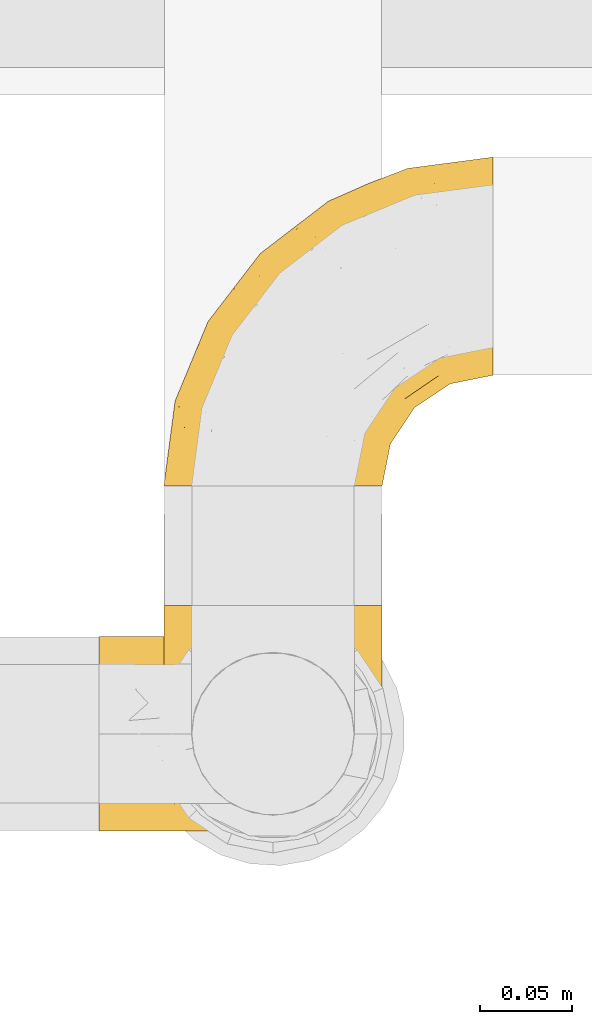
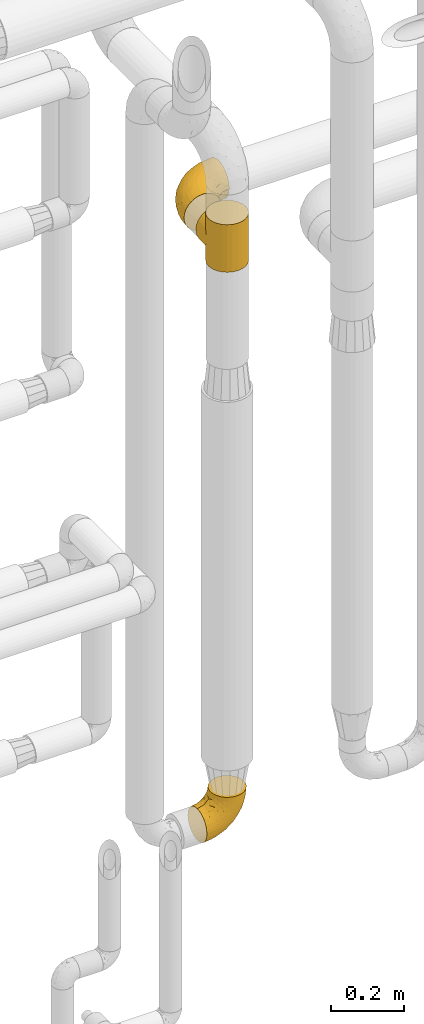
# One storey, part 462 of 827: 3 coverings.
"""IFC2X3 building model written with IfcOpenShell, lengths in millimetres."""

from ifc_helpers import new_model, entity, si_unit, converted_unit, derived_unit, direction, frame, origin, place, context, subcontext, project, spatial, faceted_brep, element, save


model = new_model("IFC2X3")

# Units and contexts
model_context = context("Model", 3, precision=0.01, world=origin(), true_north=direction((6.12303176911189e-17, 1.0)))
body_context = subcontext(model_context, "Body", "Model", "MODEL_VIEW")
ifc_project = project(units=[si_unit("LENGTHUNIT", "METRE", prefix="MILLI"), si_unit("AREAUNIT", "SQUARE_METRE"), si_unit("VOLUMEUNIT", "CUBIC_METRE"), converted_unit("PLANEANGLEUNIT", "DEGREE", entity("IfcRatioMeasure", 0.0174532925199433), si_unit("PLANEANGLEUNIT", "RADIAN"), dimensions=[0, 0, 0, 0, 0, 0, 0]), si_unit("MASSUNIT", "GRAM", prefix="KILO"), derived_unit("MASSDENSITYUNIT", [(si_unit("MASSUNIT", "GRAM", prefix="KILO"), 1), (si_unit("LENGTHUNIT", "METRE"), -3)]), derived_unit("MOMENTOFINERTIAUNIT", [(si_unit("LENGTHUNIT", "METRE"), 4)]), si_unit("TIMEUNIT", "SECOND"), si_unit("FREQUENCYUNIT", "HERTZ"), si_unit("THERMODYNAMICTEMPERATUREUNIT", "DEGREE_CELSIUS"), derived_unit("THERMALTRANSMITTANCEUNIT", [(si_unit("MASSUNIT", "GRAM", prefix="KILO"), 1), (si_unit("THERMODYNAMICTEMPERATUREUNIT", "KELVIN"), -1), (si_unit("TIMEUNIT", "SECOND"), -3)]), derived_unit("VOLUMETRICFLOWRATEUNIT", [(si_unit("LENGTHUNIT", "METRE"), 3), (si_unit("TIMEUNIT", "SECOND"), -1)]), derived_unit("MASSFLOWRATEUNIT", [(si_unit("MASSUNIT", "GRAM", prefix="KILO"), 1), (si_unit("TIMEUNIT", "SECOND"), -1)]), derived_unit("ROTATIONALFREQUENCYUNIT", [(si_unit("TIMEUNIT", "SECOND"), -1)]), si_unit("ELECTRICCURRENTUNIT", "AMPERE"), si_unit("ELECTRICVOLTAGEUNIT", "VOLT"), si_unit("POWERUNIT", "WATT"), si_unit("FORCEUNIT", "NEWTON", prefix="KILO"), si_unit("ILLUMINANCEUNIT", "LUX"), si_unit("LUMINOUSFLUXUNIT", "LUMEN"), si_unit("LUMINOUSINTENSITYUNIT", "CANDELA"), derived_unit("USERDEFINED", [(si_unit("MASSUNIT", "GRAM", prefix="KILO"), -1), (si_unit("LENGTHUNIT", "METRE"), -2), (si_unit("TIMEUNIT", "SECOND"), 3), (si_unit("LUMINOUSFLUXUNIT", "LUMEN"), 1)]), derived_unit("LINEARVELOCITYUNIT", [(si_unit("LENGTHUNIT", "METRE"), 1), (si_unit("TIMEUNIT", "SECOND"), -1)]), si_unit("PRESSUREUNIT", "PASCAL"), derived_unit("USERDEFINED", [(si_unit("LENGTHUNIT", "METRE"), -2), (si_unit("MASSUNIT", "GRAM", prefix="KILO"), 1), (si_unit("TIMEUNIT", "SECOND"), -2)]), derived_unit("LINEARFORCEUNIT", [(si_unit("MASSUNIT", "GRAM", prefix="KILO"), 1), (si_unit("LENGTHUNIT", "METRE"), 1), (si_unit("TIMEUNIT", "SECOND"), -2), (si_unit("LENGTHUNIT", "METRE"), -1)]), derived_unit("PLANARFORCEUNIT", [(si_unit("MASSUNIT", "GRAM", prefix="KILO"), 1), (si_unit("LENGTHUNIT", "METRE"), 1), (si_unit("TIMEUNIT", "SECOND"), -2), (si_unit("LENGTHUNIT", "METRE"), -2)])], contexts=[model_context])

# Site, building, storey
site_placement = place(None, origin())
site = spatial("IfcSite", under=ifc_project, at=site_placement, CompositionType="ELEMENT")
building_placement = place(site_placement, origin())
building = spatial("IfcBuilding", under=site, at=building_placement, CompositionType="ELEMENT")
storey_placement = place(building_placement, frame((0.0, 0.0, 28200.0)))
storey = spatial("IfcBuildingStorey", under=building, at=storey_placement, Name="08", CompositionType="ELEMENT", Elevation=28200.0)

# Coverings
covering_1_placement = place(storey_placement, frame((56988.97, 17438.9, 2220.0)))
element("IfcCovering", 1, at=covering_1_placement, inside=storey, Name=":ADSK_", ObjectType=":ADSK_", PredefinedType="INSULATION", context=body_context, shape_type="Brep", body=[
    faceted_brep([(120.05, 69.11, 71.99), (120.6, 61.1, 0.0), (118.57, 76.5, 0.0), (112.62, 90.85, 0.0), (115.66, 84.83, 56.27), (106.54, 99.5, 41.59), (103.17, 103.17, 0.0), (111.72, 92.36, 48.74), (120.6, 61.1, 80.0), (120.05, 69.11, 88.01), (120.6, 61.1, 160.0), (118.42, 77.05, 64.05), (100.03, 106.08, 35.01), (90.85, 112.62, 0.0), (82.85, 116.47, 24.62), (83.67, 115.6, 0.0), (76.5, 118.57, 0.0), (68.8, 119.58, 0.0), (61.1, 120.6, 0.0), (61.1, 120.6, 20.5), (68.8, 119.58, 160.0), (61.1, 120.6, 139.5), (61.1, 120.6, 160.0), (92.14, 111.85, 29.24), (72.35, 119.52, 21.57), (77.6, 118.0, 23.1), (66.72, 120.06, 21.04), (49.85, 119.52, 21.57), (53.4, 119.58, 0.0), (45.7, 118.57, 0.0), (39.34, 116.48, 24.62), (38.52, 115.6, 0.0), (31.35, 112.62, 0.0), (22.16, 106.09, 35.01), (19.02, 103.17, 0.0), (55.47, 120.06, 21.04), (53.4, 119.58, 160.0), (30.06, 111.86, 29.24), (44.6, 118.0, 23.1), (15.66, 99.51, 41.59), (10.47, 92.37, 48.73), (9.57, 90.85, 0.0), (6.54, 84.83, 56.26), (3.62, 76.5, 0.0), (2.14, 69.11, 71.99), (1.6, 61.1, 0.0), (3.77, 77.05, 64.05), (1.6, 61.1, 80.0), (2.14, 69.11, 88.01), (1.6, 61.1, 160.0), (31.35, 9.57, 160.0), (45.7, 3.62, 160.0), (61.1, 1.6, 160.0), (76.5, 3.62, 160.0), (90.85, 9.57, 160.0), (103.17, 19.02, 160.0), (112.62, 31.35, 160.0), (118.57, 45.7, 160.0), (118.57, 76.5, 160.0), (112.62, 90.85, 160.0), (103.17, 103.17, 160.0), (90.85, 112.62, 160.0), (83.67, 115.6, 160.0), (76.5, 118.57, 160.0), (45.7, 118.57, 160.0), (38.52, 115.6, 160.0), (31.35, 112.62, 160.0), (19.02, 103.17, 160.0), (9.57, 90.85, 160.0), (3.62, 76.5, 160.0), (3.62, 45.7, 160.0), (9.57, 31.35, 160.0), (19.02, 19.02, 160.0), (118.57, 45.7, 0.0), (112.62, 31.35, 0.0), (103.17, 19.02, 0.0), (90.85, 9.57, 0.0), (76.5, 3.62, 0.0), (61.1, 1.6, 0.0), (45.7, 3.62, 0.0), (31.35, 9.57, 0.0), (19.02, 19.02, 0.0), (9.57, 31.35, 0.0), (3.62, 45.7, 0.0), (118.42, 77.05, 95.95), (115.66, 84.83, 103.73), (111.72, 92.36, 111.26), (106.54, 99.5, 118.41), (100.03, 106.08, 124.99), (92.14, 111.85, 130.76), (82.85, 116.47, 135.38), (77.6, 118.0, 136.9), (72.35, 119.52, 138.43), (66.72, 120.06, 138.96), (49.85, 119.52, 138.43), (44.6, 118.0, 136.9), (39.34, 116.48, 135.38), (30.06, 111.86, 130.76), (22.16, 106.09, 124.99), (55.47, 120.06, 138.96), (15.66, 99.51, 118.41), (6.54, 84.83, 103.74), (3.77, 77.05, 95.95), (10.47, 92.37, 111.27), (118.57, 131.1, 64.6), (112.62, 131.1, 50.25), (103.17, 131.1, 37.93), (90.85, 131.1, 28.47), (83.67, 131.1, 25.5), (76.5, 131.1, 22.53), (72.65, 131.1, 22.02), (68.8, 131.1, 21.51), (64.95, 131.1, 21.01), (61.1, 131.1, 20.5), (57.25, 131.1, 21.01), (53.4, 131.1, 21.51), (49.55, 131.1, 22.02), (45.7, 131.1, 22.53), (38.52, 131.1, 25.5), (31.35, 131.1, 28.47), (19.02, 131.1, 37.93), (9.57, 131.1, 50.25), (3.62, 131.1, 64.6), (1.6, 131.1, 80.0), (3.62, 131.1, 95.4), (9.57, 131.1, 109.75), (19.02, 131.1, 122.07), (31.35, 131.1, 131.53), (38.52, 131.1, 134.5), (45.7, 131.1, 137.47), (49.55, 131.1, 137.98), (53.4, 131.1, 138.49), (57.25, 131.1, 138.99), (61.1, 131.1, 139.5), (64.95, 131.1, 138.99), (68.8, 131.1, 138.49), (72.65, 131.1, 137.98), (76.5, 131.1, 137.47), (83.67, 131.1, 134.5), (90.85, 131.1, 131.53), (103.17, 131.1, 122.07), (112.62, 131.1, 109.75), (118.57, 131.1, 95.4), (120.6, 131.1, 80.0)], [[[0, 1, 2]], [[2, 3, 4]], [[5, 3, 6]], [[5, 7, 3]], [[0, 8, 1]], [[8, 9, 10]], [[4, 11, 2]], [[7, 4, 3]], [[0, 2, 11]], [[12, 6, 13]], [[14, 13, 15, 16]], [[17, 18, 19]], [[20, 21, 22]], [[23, 12, 13]], [[16, 24, 25, 14]], [[17, 19, 26, 24]], [[24, 16, 17]], [[23, 13, 14]], [[6, 12, 5]], [[27, 28, 29]], [[30, 29, 31, 32]], [[33, 32, 34]], [[28, 27, 35, 19]], [[19, 18, 28]], [[22, 21, 36]], [[37, 30, 32]], [[33, 37, 32]], [[29, 30, 38, 27]], [[34, 39, 33]], [[40, 39, 41]], [[41, 39, 34]], [[42, 41, 43]], [[44, 43, 45]], [[42, 40, 41]], [[44, 46, 43]], [[47, 44, 45]], [[48, 47, 49]], [[42, 43, 46]], [[50, 51, 52, 53, 54, 55, 56, 57, 10, 58, 59, 60, 61, 62, 63, 20, 22, 36, 64, 65, 66, 67, 68, 69, 49, 70, 71, 72]], [[73, 74, 75, 76, 77, 78, 79, 80, 81, 82, 83, 45, 43, 41, 34, 32, 31, 29, 28, 18, 17, 16, 15, 13, 6, 3, 2, 1]], [[76, 75, 55, 54]], [[52, 78, 77, 53]], [[53, 77, 76, 54]], [[56, 74, 73, 57]], [[1, 8, 10, 57, 73]], [[55, 75, 74, 56]], [[84, 85, 58]], [[9, 84, 58]], [[10, 9, 58]], [[59, 86, 87]], [[59, 58, 85]], [[59, 87, 60]], [[86, 59, 85]], [[88, 89, 61]], [[90, 63, 62, 61]], [[63, 90, 91, 92]], [[20, 92, 93, 21]], [[89, 90, 61]], [[60, 88, 61]], [[92, 20, 63]], [[88, 60, 87]], [[64, 94, 95, 96]], [[94, 64, 36]], [[97, 98, 66]], [[96, 66, 65, 64]], [[96, 97, 66]], [[36, 21, 99, 94]], [[98, 67, 66]], [[98, 100, 67]], [[101, 102, 69]], [[102, 48, 69]], [[100, 103, 68]], [[101, 68, 103]], [[101, 69, 68]], [[48, 49, 69]], [[100, 68, 67]], [[47, 45, 83, 70, 49]], [[70, 83, 82, 71]], [[82, 81, 72, 71]], [[72, 81, 80, 50]], [[50, 80, 79, 51]], [[51, 79, 78, 52]], [[104, 105, 106, 107, 108, 109, 110, 111, 112, 113, 114, 115, 116, 117, 118, 119, 120, 121, 122, 123, 124, 125, 126, 127, 128, 129, 130, 131, 132, 133, 134, 135, 136, 137, 138, 139, 140, 141, 142, 143]], [[24, 111, 110, 109]], [[107, 106, 12]], [[19, 112, 26]], [[14, 108, 107]], [[112, 19, 113]], [[112, 111, 26]], [[108, 25, 109]], [[23, 14, 107]], [[12, 23, 107]], [[25, 108, 14]], [[24, 109, 25]], [[106, 5, 12]], [[7, 5, 105]], [[105, 5, 106]], [[4, 105, 104]], [[0, 104, 143]], [[4, 7, 105]], [[0, 11, 104]], [[8, 0, 143]], [[4, 104, 11]], [[111, 24, 26]], [[9, 143, 142]], [[142, 141, 85]], [[87, 141, 140]], [[87, 86, 141]], [[9, 8, 143]], [[93, 135, 134]], [[85, 84, 142]], [[86, 85, 141]], [[9, 142, 84]], [[21, 134, 133]], [[88, 140, 139]], [[138, 137, 91]], [[21, 93, 134]], [[137, 92, 91]], [[89, 88, 139]], [[90, 139, 138]], [[90, 138, 91]], [[92, 135, 93]], [[92, 137, 136, 135]], [[89, 139, 90]], [[140, 88, 87]], [[94, 131, 130, 129]], [[96, 128, 127]], [[98, 127, 126]], [[132, 21, 133]], [[132, 131, 99]], [[128, 95, 129]], [[97, 96, 127]], [[98, 97, 127]], [[95, 128, 96]], [[94, 129, 95]], [[126, 100, 98]], [[103, 100, 125]], [[125, 100, 126]], [[101, 125, 124]], [[48, 124, 123]], [[101, 103, 125]], [[48, 102, 124]], [[47, 48, 123]], [[101, 124, 102]], [[21, 132, 99]], [[131, 94, 99]], [[44, 123, 122]], [[122, 121, 42]], [[39, 121, 120]], [[39, 40, 121]], [[44, 47, 123]], [[35, 115, 114]], [[42, 46, 122]], [[40, 42, 121]], [[44, 122, 46]], [[19, 114, 113]], [[33, 120, 119]], [[118, 117, 38]], [[19, 35, 114]], [[117, 27, 38]], [[37, 33, 119]], [[30, 119, 118]], [[30, 118, 38]], [[27, 115, 35]], [[27, 117, 116, 115]], [[37, 119, 30]], [[120, 33, 39]]]),
])
covering_2_placement = place(storey_placement, frame((56988.97, 17633.5, 2238.9)))
element("IfcCovering", 2, at=covering_2_placement, inside=storey, Name=":ADSK_", ObjectType=":ADSK_", PredefinedType="INSULATION", context=body_context, shape_type="Brep", body=[
    faceted_brep([(47.85, 1.6, 119.1), (35.28, 1.6, 114.7), (23.99, 1.6, 107.61), (14.57, 1.6, 98.19), (7.48, 1.6, 86.9), (3.08, 1.6, 74.32), (1.6, 1.6, 61.1), (3.09, 1.6, 47.85), (7.49, 1.6, 35.28), (14.58, 1.6, 23.99), (24.0, 1.6, 14.57), (35.29, 1.6, 7.48), (47.87, 1.6, 3.08), (61.1, 1.6, 1.6), (74.34, 1.6, 3.09), (86.92, 1.6, 7.49), (98.2, 1.6, 14.58), (107.62, 1.6, 24.0), (114.71, 1.6, 35.29), (119.11, 1.6, 47.87), (120.6, 1.6, 61.1), (119.1, 1.6, 74.34), (114.7, 1.6, 86.92), (107.61, 1.6, 98.2), (98.19, 1.6, 107.62), (86.9, 1.6, 114.71), (74.32, 1.6, 119.11), (61.1, 1.6, 120.6), (181.1, 64.12, 45.7), (181.1, 70.07, 31.35), (181.1, 79.52, 19.02), (181.1, 91.85, 9.57), (181.1, 106.2, 3.62), (181.1, 121.6, 1.6), (181.1, 137.0, 3.62), (181.1, 151.35, 9.57), (181.1, 163.67, 19.02), (181.1, 173.12, 31.35), (181.1, 179.07, 45.7), (181.1, 181.1, 61.1), (181.1, 179.07, 76.5), (181.1, 173.12, 90.85), (181.1, 163.67, 103.17), (181.1, 151.35, 112.62), (181.1, 137.0, 118.57), (181.1, 121.6, 120.6), (181.1, 106.2, 118.57), (181.1, 91.85, 112.62), (181.1, 79.52, 103.17), (181.1, 70.07, 90.85), (181.1, 64.12, 76.5), (181.1, 62.1, 61.1), (149.36, 166.85, 95.88), (137.95, 171.8, 82.3), (112.73, 156.7, 94.1), (142.53, 175.89, 71.89), (134.64, 174.98, 61.1), (30.78, 34.39, 110.03), (74.16, 141.86, 80.11), (91.35, 157.05, 61.1), (54.17, 128.52, 61.1), (109.16, 125.77, 115.76), (132.51, 142.49, 113.03), (100.6, 137.62, 106.83), (143.49, 133.72, 118.0), (118.25, 116.57, 119.56), (53.89, 116.34, 91.22), (84.22, 137.54, 97.67), (106.32, 160.1, 83.16), (113.45, 166.8, 71.84), (137.68, 154.26, 106.27), (7.71, 48.05, 61.1), (9.86, 44.99, 79.29), (25.56, 75.77, 89.43), (40.03, 109.34, 76.37), (20.36, 78.35, 73.84), (85.71, 96.98, 118.7), (75.88, 106.86, 113.14), (51.26, 67.36, 114.84), (56.83, 49.85, 119.09), (84.01, 72.13, 120.6), (110.56, 98.68, 120.6), (127.29, 107.2, 120.6), (144.01, 115.72, 120.6), (25.64, 91.35, 61.1), (22.95, 45.24, 101.09), (40.15, 73.45, 106.71), (12.95, 33.95, 91.36), (42.03, 32.97, 116.15), (63.41, 16.23, 120.6), (66.97, 38.68, 120.6), (31.89, 74.48, 98.77), (97.29, 85.4, 120.6), (67.3, 115.39, 104.27), (75.49, 55.4, 120.6), (166.46, 119.28, 120.6), (141.36, 85.98, 114.26), (121.72, 71.16, 113.3), (138.16, 70.35, 106.08), (159.88, 103.0, 118.29), (128.08, 94.6, 119.17), (126.23, 55.86, 102.39), (110.87, 81.81, 119.07), (162.96, 60.95, 74.66), (146.61, 52.54, 72.06), (157.94, 57.49, 61.1), (102.08, 24.83, 107.18), (112.03, 37.73, 103.18), (107.36, 50.74, 111.64), (162.91, 87.65, 111.23), (157.88, 74.24, 101.44), (118.07, 15.74, 82.78), (111.72, 20.12, 95.99), (151.58, 61.93, 88.46), (167.61, 65.86, 85.34), (132.93, 40.95, 75.22), (138.32, 44.38, 61.1), (90.2, 38.05, 116.35), (87.09, 55.63, 119.46), (98.46, 56.15, 116.78), (122.87, 31.75, 85.13), (132.83, 49.11, 89.52), (76.52, 20.72, 119.0), (117.49, 32.8, 94.63), (90.0, 18.32, 113.92), (123.48, 24.08, 73.67), (125.2, 24.75, 61.1), (97.44, 70.12, 119.4), (139.94, 61.67, 97.35), (79.72, 41.55, 119.56), (145.56, 96.92, 117.72), (152.47, 81.07, 108.82), (138.17, 70.33, 16.12), (126.24, 55.85, 19.81), (121.74, 71.15, 8.9), (111.73, 20.12, 26.21), (102.09, 24.84, 15.02), (139.94, 61.65, 24.86), (90.22, 38.08, 5.84), (79.72, 41.53, 2.63), (87.08, 55.63, 2.73), (132.91, 40.93, 46.99), (162.97, 60.95, 47.54), (167.61, 65.86, 36.85), (162.91, 87.65, 10.96), (152.47, 81.07, 13.37), (141.36, 85.98, 7.93), (128.08, 94.6, 3.02), (112.07, 84.2, 2.89), (110.56, 98.68, 1.6), (159.88, 103.0, 3.9), (166.46, 119.28, 1.6), (121.68, 40.95, 26.96), (122.86, 31.73, 37.08), (157.88, 74.24, 20.75), (107.38, 50.74, 10.56), (146.61, 52.54, 50.11), (112.05, 37.73, 19.02), (123.48, 24.06, 48.54), (101.72, 68.67, 3.81), (90.01, 18.33, 8.27), (145.56, 96.92, 4.47), (118.07, 15.72, 39.43), (76.53, 20.72, 3.19), (132.81, 49.08, 32.68), (66.97, 38.68, 1.6), (63.41, 16.23, 1.6), (75.49, 55.4, 1.6), (97.07, 51.76, 5.87), (97.29, 85.4, 1.6), (144.01, 115.72, 1.6), (127.29, 107.2, 1.6), (84.01, 72.13, 1.6), (151.59, 61.93, 33.73), (112.73, 156.7, 28.09), (149.36, 166.85, 26.31), (137.68, 154.26, 15.92), (132.51, 142.49, 9.16), (142.53, 175.89, 50.3), (137.95, 171.8, 39.89), (113.45, 166.8, 50.35), (118.25, 116.57, 2.63), (100.6, 137.62, 15.36), (40.03, 109.34, 45.82), (53.89, 116.34, 30.97), (25.56, 75.76, 32.75), (85.71, 96.98, 3.49), (143.49, 133.72, 4.19), (106.32, 160.1, 39.03), (21.51, 78.71, 44.85), (9.86, 44.98, 42.89), (74.16, 141.86, 42.08), (42.04, 32.97, 6.03), (56.84, 49.86, 3.1), (109.16, 125.77, 6.43), (75.88, 106.86, 9.05), (30.8, 34.39, 12.15), (22.96, 45.23, 21.09), (84.22, 137.54, 24.52), (12.96, 33.95, 30.82), (51.28, 67.37, 7.35), (40.16, 73.45, 15.47), (67.3, 115.39, 17.92), (31.9, 74.47, 23.41)], [[[0, 1, 2, 3, 4, 5, 6, 7, 8, 9, 10, 11, 12, 13, 14, 15, 16, 17, 18, 19, 20, 21, 22, 23, 24, 25, 26, 27]], [[28, 29, 30, 31, 32, 33, 34, 35, 36, 37, 38, 39, 40, 41, 42, 43, 44, 45, 46, 47, 48, 49, 50, 51]], [[52, 53, 54]], [[55, 39, 56]], [[57, 2, 1]], [[58, 59, 60]], [[61, 62, 63]], [[64, 61, 65]], [[58, 66, 67]], [[53, 68, 54]], [[41, 40, 53]], [[53, 69, 68]], [[70, 42, 52]], [[42, 41, 52]], [[71, 5, 72]], [[73, 74, 75]], [[43, 70, 62]], [[45, 44, 64]], [[76, 77, 78]], [[79, 80, 76]], [[65, 81, 82, 83]], [[74, 60, 84]], [[85, 2, 57]], [[85, 57, 86]], [[2, 85, 3]], [[42, 70, 43]], [[5, 4, 72]], [[72, 87, 73]], [[4, 3, 87]], [[5, 71, 6]], [[75, 74, 84]], [[64, 62, 61]], [[79, 78, 88]], [[54, 67, 63]], [[74, 58, 60]], [[65, 76, 81]], [[79, 27, 89, 90]], [[75, 71, 72]], [[85, 86, 91]], [[78, 57, 88]], [[56, 69, 55]], [[76, 78, 79]], [[76, 80, 92, 81]], [[77, 76, 61]], [[69, 56, 59]], [[4, 87, 72]], [[91, 66, 73]], [[58, 74, 66]], [[3, 85, 87]], [[73, 87, 85]], [[88, 57, 1]], [[86, 57, 78]], [[77, 86, 78]], [[93, 66, 91]], [[73, 66, 74]], [[67, 93, 63]], [[1, 0, 88]], [[0, 27, 79]], [[0, 79, 88]], [[79, 90, 94, 80]], [[64, 83, 95, 45]], [[76, 65, 61]], [[83, 64, 65]], [[62, 44, 43]], [[62, 64, 44]], [[63, 62, 70]], [[54, 63, 70]], [[63, 93, 77]], [[63, 77, 61]], [[77, 93, 86]], [[67, 54, 68]], [[66, 93, 67]], [[53, 52, 41]], [[70, 52, 54]], [[58, 69, 59]], [[55, 69, 53]], [[69, 58, 68]], [[67, 68, 58]], [[53, 40, 55]], [[39, 55, 40]], [[71, 75, 84]], [[73, 75, 72]], [[91, 86, 93]], [[73, 85, 91]], [[96, 97, 98]], [[83, 99, 95]], [[82, 81, 100]], [[95, 99, 46]], [[101, 98, 97]], [[47, 46, 99]], [[97, 100, 102]], [[103, 104, 105]], [[106, 107, 108]], [[109, 48, 47]], [[48, 110, 49]], [[108, 101, 97]], [[111, 112, 22]], [[51, 50, 103]], [[113, 103, 114]], [[23, 22, 112]], [[115, 116, 104]], [[108, 117, 106]], [[112, 106, 23]], [[94, 118, 80]], [[108, 119, 117]], [[120, 115, 121]], [[112, 107, 106]], [[25, 122, 26]], [[122, 89, 26]], [[101, 123, 121]], [[109, 110, 48]], [[124, 25, 24]], [[125, 20, 126]], [[120, 111, 125]], [[110, 113, 114]], [[127, 97, 102]], [[106, 24, 23]], [[125, 115, 120]], [[111, 22, 21]], [[126, 115, 125]], [[117, 124, 106]], [[110, 98, 128]], [[117, 129, 124]], [[117, 118, 129]], [[100, 97, 96]], [[124, 122, 25]], [[83, 82, 130]], [[99, 130, 109]], [[100, 81, 102]], [[100, 130, 82]], [[130, 100, 96]], [[81, 92, 102]], [[127, 80, 118]], [[21, 20, 125]], [[111, 120, 123]], [[21, 125, 111]], [[115, 126, 116]], [[104, 116, 105]], [[101, 107, 123]], [[104, 121, 115]], [[128, 121, 113]], [[105, 51, 103]], [[121, 104, 113]], [[114, 103, 50]], [[113, 104, 103]], [[106, 124, 24]], [[94, 129, 118]], [[123, 107, 112]], [[101, 108, 107]], [[99, 109, 47]], [[131, 109, 96]], [[89, 122, 90]], [[89, 27, 26]], [[122, 129, 90]], [[97, 127, 119]], [[119, 127, 118]], [[102, 92, 127]], [[90, 129, 94]], [[80, 127, 92]], [[124, 129, 122]], [[117, 119, 118]], [[97, 119, 108]], [[50, 49, 114]], [[110, 114, 49]], [[109, 130, 96]], [[130, 99, 83]], [[128, 98, 101]], [[98, 110, 131]], [[121, 128, 101]], [[110, 128, 113]], [[46, 45, 95]], [[111, 123, 112]], [[121, 123, 120]], [[98, 131, 96]], [[110, 109, 131]], [[132, 133, 134]], [[135, 17, 136]], [[132, 137, 133]], [[138, 139, 140]], [[126, 141, 116]], [[105, 142, 51]], [[16, 136, 17]], [[142, 143, 28]], [[144, 145, 146]], [[147, 148, 149]], [[31, 150, 32]], [[150, 151, 32]], [[135, 152, 153]], [[30, 29, 154]], [[155, 136, 138]], [[31, 30, 144]], [[156, 116, 141]], [[136, 155, 157]], [[126, 158, 141]], [[159, 148, 134]], [[20, 19, 158]], [[156, 142, 105]], [[160, 136, 16]], [[147, 161, 146]], [[135, 18, 17]], [[18, 162, 19]], [[136, 157, 135]], [[146, 145, 132]], [[160, 163, 139]], [[16, 15, 160]], [[15, 14, 163]], [[164, 141, 153]], [[133, 155, 134]], [[152, 135, 157]], [[165, 163, 166]], [[163, 14, 166]], [[162, 135, 153]], [[29, 143, 154]], [[165, 167, 139]], [[162, 158, 19]], [[159, 134, 155]], [[167, 140, 139]], [[140, 168, 138]], [[159, 169, 148]], [[144, 150, 31]], [[161, 170, 150]], [[171, 170, 161]], [[149, 171, 147]], [[134, 147, 146]], [[134, 148, 147]], [[135, 162, 18]], [[169, 159, 172]], [[169, 149, 148]], [[158, 162, 153]], [[158, 153, 141]], [[158, 126, 20]], [[153, 152, 164]], [[116, 156, 105]], [[137, 164, 133]], [[156, 164, 173]], [[164, 156, 141]], [[142, 28, 51]], [[156, 173, 142]], [[143, 142, 173]], [[163, 160, 15]], [[136, 160, 138]], [[155, 133, 157]], [[133, 164, 152]], [[154, 144, 30]], [[144, 146, 161]], [[14, 13, 166]], [[172, 159, 140]], [[140, 167, 172]], [[168, 159, 155]], [[160, 139, 138]], [[165, 139, 163]], [[154, 143, 173]], [[29, 28, 143]], [[171, 161, 147]], [[144, 161, 150]], [[159, 168, 140]], [[155, 138, 168]], [[146, 132, 134]], [[137, 154, 173]], [[154, 137, 132]], [[164, 137, 173]], [[151, 150, 170]], [[151, 33, 32]], [[133, 152, 157]], [[144, 154, 145]], [[132, 145, 154]], [[174, 175, 176]], [[35, 34, 177]], [[178, 179, 180]], [[181, 170, 171, 149]], [[176, 182, 174]], [[183, 184, 185]], [[186, 149, 169, 172]], [[187, 33, 151, 170]], [[179, 188, 180]], [[34, 187, 177]], [[39, 38, 178]], [[189, 185, 190]], [[184, 183, 191]], [[175, 179, 37]], [[38, 37, 179]], [[35, 176, 36]], [[180, 59, 56]], [[192, 193, 12]], [[37, 36, 175]], [[181, 187, 170]], [[181, 186, 194]], [[176, 177, 182]], [[8, 7, 190]], [[194, 186, 195]], [[13, 12, 193]], [[196, 192, 11]], [[10, 9, 197]], [[60, 183, 84]], [[174, 182, 198]], [[197, 196, 10]], [[193, 172, 167, 165]], [[8, 199, 9]], [[189, 183, 185]], [[60, 59, 191]], [[200, 196, 201]], [[190, 199, 8]], [[7, 6, 71]], [[10, 196, 11]], [[202, 203, 184]], [[199, 185, 197]], [[7, 71, 190]], [[183, 60, 191]], [[189, 71, 84]], [[193, 186, 172]], [[200, 201, 195]], [[180, 191, 59]], [[185, 199, 190]], [[197, 9, 199]], [[201, 196, 197]], [[192, 196, 200]], [[203, 201, 197]], [[195, 201, 202]], [[191, 188, 198]], [[202, 201, 203]], [[193, 192, 200]], [[12, 11, 192]], [[186, 193, 200]], [[193, 165, 166, 13]], [[186, 181, 149]], [[187, 181, 194]], [[187, 194, 177]], [[187, 34, 33]], [[194, 195, 182]], [[35, 177, 176]], [[194, 182, 177]], [[182, 202, 198]], [[200, 195, 186]], [[182, 195, 202]], [[202, 184, 198]], [[191, 198, 184]], [[176, 175, 36]], [[179, 175, 174]], [[178, 180, 56]], [[179, 174, 188]], [[198, 188, 174]], [[191, 180, 188]], [[39, 178, 56]], [[38, 179, 178]], [[71, 189, 190]], [[84, 183, 189]], [[197, 185, 203]], [[184, 203, 185]]]),
])
covering_3_placement = place(storey_placement, frame((56953.47, 17445.35, 297.85)))
element("IfcCovering", 3, at=covering_3_placement, inside=storey, Name=":ADSK_", ObjectType=":ADSK_", PredefinedType="INSULATION", context=body_context, shape_type="Brep", body=[
    faceted_brep([(148.32, 42.85, 149.65), (149.65, 54.65, 149.65), (148.31, 66.46, 149.65), (144.39, 77.67, 149.65), (138.06, 87.73, 149.65), (129.66, 96.13, 149.65), (119.6, 102.45, 149.65), (108.39, 106.37, 149.65), (96.6, 107.7, 149.65), (84.79, 106.36, 149.65), (73.57, 102.44, 149.65), (63.51, 96.11, 149.65), (55.11, 87.71, 149.65), (48.79, 77.65, 149.65), (44.87, 66.44, 149.65), (43.55, 54.65, 149.65), (44.88, 42.84, 149.65), (48.8, 31.62, 149.65), (55.13, 21.56, 149.65), (63.53, 13.16, 149.65), (73.59, 6.84, 149.65), (84.8, 2.92, 149.65), (96.6, 1.6, 149.65), (108.41, 2.93, 149.65), (119.62, 6.85, 149.65), (129.68, 13.18, 149.65), (138.08, 21.58, 149.65), (144.4, 31.64, 149.65), (1.6, 68.38, 105.89), (1.6, 81.17, 100.59), (1.6, 92.16, 92.16), (1.6, 100.59, 81.17), (1.6, 105.89, 68.38), (1.6, 107.7, 54.65), (1.6, 105.89, 40.91), (1.6, 100.59, 28.12), (1.6, 92.16, 17.13), (1.6, 81.17, 8.7), (1.6, 68.38, 3.4), (1.6, 54.65, 1.6), (1.6, 40.91, 3.4), (1.6, 28.12, 8.7), (1.6, 17.13, 17.13), (1.6, 8.7, 28.12), (1.6, 3.4, 40.91), (1.6, 1.6, 54.65), (1.6, 3.4, 68.38), (1.6, 8.7, 81.17), (1.6, 17.13, 92.16), (1.6, 28.12, 100.59), (1.6, 40.91, 105.89), (1.6, 54.65, 107.7), (27.97, 23.76, 14.05), (37.09, 35.87, 9.45), (58.27, 25.52, 22.36), (27.13, 45.07, 4.7), (39.91, 54.65, 6.64), (109.11, 12.57, 81.47), (94.41, 15.93, 56.83), (110.94, 24.82, 64.02), (89.69, 37.92, 34.04), (75.62, 54.65, 21.43), (106.28, 54.65, 44.96), (60.12, 5.82, 49.8), (41.41, 8.38, 35.43), (63.22, 10.19, 42.1), (32.05, 3.86, 43.59), (52.13, 2.5, 57.88), (123.27, 19.48, 91.8), (129.32, 29.7, 88.01), (138.3, 28.0, 115.65), (62.95, 35.28, 18.94), (55.89, 45.15, 12.83), (37.4, 14.54, 24.96), (144.6, 54.65, 111.33), (142.66, 38.55, 113.8), (117.85, 40.99, 60.89), (134.01, 43.24, 86.24), (89.25, 8.56, 65.84), (103.34, 2.51, 124.58), (113.52, 5.69, 121.36), (57.43, 1.6, 72.79), (44.19, 1.6, 66.04), (30.95, 1.6, 59.29), (77.98, 3.22, 73.26), (132.66, 18.7, 121.69), (121.52, 11.86, 109.82), (86.93, 24.78, 40.11), (68.4, 15.99, 36.57), (78.45, 1.6, 93.81), (67.94, 1.6, 83.3), (94.53, 1.6, 136.6), (91.95, 1.6, 120.29), (93.36, 2.5, 99.11), (85.2, 1.6, 107.05), (101.45, 5.82, 91.12), (129.81, 54.65, 75.62), (16.27, 1.6, 56.97), (42.46, 32.3, 126.65), (40.4, 25.01, 116.55), (49.71, 18.18, 120.09), (39.4, 3.03, 76.06), (31.26, 6.69, 83.69), (27.7, 3.21, 71.88), (16.7, 2.73, 66.92), (70.67, 3.93, 110.43), (81.69, 2.55, 121.31), (16.68, 7.7, 81.0), (22.57, 54.65, 113.32), (14.26, 54.65, 111.09), (17.68, 41.58, 109.14), (19.58, 17.93, 95.86), (33.49, 14.97, 99.07), (33.01, 22.2, 106.92), (40.69, 43.45, 131.39), (40.15, 54.65, 136.98), (37.93, 54.65, 128.67), (31.04, 40.37, 117.07), (45.29, 8.47, 96.39), (23.55, 29.46, 106.61), (11.36, 32.17, 103.72), (59.1, 3.39, 92.14), (57.42, 7.76, 107.13), (68.96, 2.57, 98.03), (20.38, 11.54, 88.38), (72.46, 6.21, 130.66), (83.66, 2.9, 135.45), (60.66, 11.19, 123.57), (61.01, 14.27, 137.75), (51.85, 22.4, 133.2), (46.07, 34.87, 138.8), (30.25, 54.65, 120.99), (46.65, 4.01, 84.53), (43.0, 16.42, 108.72), (19.58, 91.36, 95.86), (72.44, 103.07, 130.67), (17.67, 67.71, 109.13), (78.45, 107.7, 93.81), (68.97, 106.72, 98.02), (70.65, 105.35, 110.43), (40.69, 65.83, 131.4), (42.45, 76.97, 126.66), (31.04, 68.91, 117.08), (42.99, 92.85, 108.74), (45.18, 100.82, 96.31), (33.46, 94.28, 99.11), (60.64, 98.08, 123.58), (57.37, 101.51, 107.12), (57.43, 107.7, 72.79), (44.19, 107.7, 66.04), (39.35, 106.25, 76.07), (16.27, 107.7, 56.97), (16.7, 106.56, 66.92), (91.95, 107.7, 120.29), (85.2, 107.7, 107.05), (81.68, 106.74, 121.26), (46.68, 105.31, 84.46), (31.26, 102.6, 83.69), (16.68, 101.59, 81.0), (27.7, 106.08, 71.88), (60.99, 95.01, 137.76), (51.84, 86.87, 133.21), (40.41, 84.27, 116.58), (49.72, 91.11, 120.1), (46.06, 74.4, 138.81), (94.53, 107.7, 136.6), (11.35, 77.12, 103.72), (33.02, 87.06, 106.96), (83.65, 106.38, 135.44), (20.38, 97.75, 88.38), (67.94, 107.7, 83.3), (23.53, 79.83, 106.6), (59.12, 105.91, 92.12), (30.95, 107.7, 59.29), (58.27, 83.77, 22.36), (27.97, 85.53, 14.05), (37.4, 94.75, 24.96), (41.41, 100.91, 35.43), (27.21, 64.22, 4.71), (37.09, 73.42, 9.45), (53.2, 64.15, 11.79), (52.13, 106.79, 57.88), (103.34, 106.79, 124.57), (113.5, 103.61, 121.37), (101.45, 103.47, 91.12), (94.41, 93.36, 56.83), (109.08, 96.75, 81.48), (110.95, 84.48, 64.05), (93.36, 106.79, 99.11), (77.98, 106.07, 73.26), (32.05, 105.43, 43.59), (64.63, 73.44, 19.5), (123.25, 89.82, 91.8), (132.65, 90.61, 121.7), (129.32, 79.61, 88.04), (139.96, 81.34, 123.34), (117.85, 68.3, 60.89), (89.69, 71.37, 34.04), (121.51, 97.44, 109.85), (63.23, 99.1, 42.1), (89.17, 100.74, 65.78), (142.66, 70.76, 113.81), (68.4, 93.3, 36.57), (86.94, 84.5, 40.12), (60.12, 103.47, 49.8), (133.2, 68.73, 86.08)], [[[0, 1, 2, 3, 4, 5, 6, 7, 8, 9, 10, 11, 12, 13, 14, 15, 16, 17, 18, 19, 20, 21, 22, 23, 24, 25, 26, 27]], [[28, 29, 30, 31, 32, 33, 34, 35, 36, 37, 38, 39, 40, 41, 42, 43, 44, 45, 46, 47, 48, 49, 50, 51]], [[52, 53, 54]], [[55, 39, 56]], [[57, 58, 59]], [[60, 61, 62]], [[63, 64, 65]], [[66, 63, 67]], [[68, 69, 70]], [[53, 71, 54]], [[41, 40, 53]], [[53, 72, 71]], [[73, 42, 52]], [[42, 41, 52]], [[74, 0, 75]], [[69, 76, 77]], [[43, 73, 64]], [[45, 44, 66]], [[57, 78, 58]], [[23, 79, 80]], [[67, 81, 82, 83]], [[67, 84, 81]], [[24, 23, 80]], [[25, 85, 26]], [[86, 85, 25]], [[42, 73, 43]], [[0, 27, 75]], [[25, 24, 86]], [[70, 26, 85]], [[0, 74, 1]], [[68, 85, 86]], [[66, 64, 63]], [[60, 59, 87]], [[54, 87, 88]], [[76, 60, 62]], [[84, 89, 90, 81]], [[79, 22, 91, 92]], [[77, 74, 75]], [[93, 92, 94, 89]], [[80, 86, 24]], [[40, 55, 53]], [[76, 59, 60]], [[93, 84, 95]], [[76, 62, 96]], [[55, 72, 53]], [[70, 27, 26]], [[75, 70, 69]], [[78, 84, 63]], [[93, 79, 92]], [[95, 86, 80]], [[77, 76, 96]], [[59, 69, 68]], [[57, 68, 86]], [[68, 57, 59]], [[59, 58, 87]], [[76, 69, 59]], [[88, 87, 58]], [[87, 54, 71]], [[86, 95, 57]], [[78, 57, 95]], [[84, 78, 95]], [[78, 63, 65]], [[58, 78, 65]], [[54, 88, 73]], [[84, 93, 89]], [[79, 95, 80]], [[79, 93, 95]], [[22, 79, 23]], [[66, 83, 97, 45]], [[84, 67, 63]], [[83, 66, 67]], [[64, 44, 43]], [[64, 66, 44]], [[65, 73, 88]], [[53, 52, 41]], [[73, 52, 54]], [[73, 65, 64]], [[65, 88, 58]], [[39, 55, 40]], [[72, 55, 56]], [[56, 61, 72]], [[60, 72, 61]], [[72, 60, 71]], [[87, 71, 60]], [[27, 70, 75]], [[68, 70, 85]], [[74, 77, 96]], [[69, 77, 75]], [[98, 99, 100]], [[46, 45, 97]], [[101, 102, 103]], [[103, 104, 83]], [[105, 94, 106]], [[107, 103, 102]], [[108, 109, 51, 110]], [[111, 112, 113]], [[114, 115, 116]], [[47, 104, 107]], [[110, 117, 108]], [[49, 48, 111]], [[102, 118, 112]], [[119, 120, 111]], [[50, 49, 120]], [[121, 122, 118]], [[105, 123, 89]], [[124, 48, 107]], [[20, 19, 125]], [[121, 81, 90]], [[117, 119, 99]], [[21, 20, 126]], [[22, 21, 91]], [[105, 125, 127]], [[110, 51, 50]], [[19, 128, 125]], [[16, 15, 115]], [[129, 98, 100]], [[126, 91, 21]], [[128, 129, 127]], [[122, 123, 105]], [[114, 117, 98]], [[17, 16, 130]], [[18, 128, 19]], [[129, 18, 17]], [[125, 106, 126]], [[115, 114, 16]], [[130, 129, 17]], [[114, 98, 130]], [[117, 116, 131, 108]], [[99, 119, 113]], [[122, 121, 123]], [[92, 126, 106]], [[105, 127, 122]], [[132, 121, 118]], [[114, 130, 16]], [[129, 130, 98]], [[50, 120, 110]], [[129, 128, 18]], [[125, 128, 127]], [[125, 126, 20]], [[91, 126, 92]], [[105, 89, 94]], [[105, 106, 125]], [[94, 92, 106]], [[100, 122, 127]], [[118, 122, 133]], [[112, 118, 133]], [[132, 118, 102]], [[132, 102, 101]], [[81, 121, 132]], [[82, 103, 83]], [[132, 101, 81]], [[104, 47, 46]], [[124, 107, 102]], [[48, 47, 107]], [[113, 112, 133]], [[112, 111, 124]], [[99, 113, 133]], [[111, 113, 119]], [[99, 133, 100]], [[117, 99, 98]], [[122, 100, 133]], [[127, 129, 100]], [[103, 82, 101]], [[81, 101, 82]], [[112, 124, 102]], [[48, 124, 111]], [[104, 103, 107]], [[46, 97, 104]], [[111, 120, 49]], [[83, 104, 97]], [[110, 120, 119]], [[117, 110, 119]], [[116, 117, 114]], [[89, 123, 90]], [[90, 123, 121]], [[30, 29, 134]], [[11, 10, 135]], [[51, 109, 108, 136]], [[137, 138, 139]], [[140, 141, 142]], [[143, 144, 145]], [[146, 139, 147]], [[148, 149, 150]], [[151, 32, 152]], [[153, 154, 155]], [[156, 150, 157]], [[158, 157, 159]], [[108, 142, 136]], [[31, 158, 152]], [[160, 161, 12]], [[162, 163, 143]], [[140, 142, 116]], [[142, 141, 162]], [[14, 164, 140]], [[14, 140, 115]], [[9, 8, 165]], [[160, 12, 11]], [[141, 164, 161]], [[13, 12, 161]], [[14, 115, 15]], [[28, 166, 29]], [[135, 139, 146]], [[141, 163, 162]], [[135, 146, 160]], [[143, 167, 162]], [[29, 166, 134]], [[116, 142, 108, 131]], [[165, 153, 168]], [[10, 9, 168]], [[168, 135, 10]], [[138, 147, 139]], [[158, 169, 157]], [[14, 13, 164]], [[116, 115, 140]], [[145, 167, 143]], [[135, 160, 11]], [[168, 153, 155]], [[138, 137, 170]], [[157, 144, 156]], [[147, 144, 143]], [[161, 164, 13]], [[140, 164, 141]], [[142, 171, 136]], [[136, 171, 166]], [[161, 160, 146]], [[165, 168, 9]], [[155, 139, 135]], [[139, 154, 137]], [[168, 155, 135]], [[139, 155, 154]], [[144, 147, 172]], [[163, 147, 143]], [[156, 144, 172]], [[157, 169, 145]], [[172, 148, 156]], [[173, 159, 149]], [[159, 157, 150]], [[152, 159, 173]], [[159, 152, 158]], [[31, 30, 158]], [[169, 30, 134]], [[157, 145, 144]], [[167, 134, 171]], [[134, 167, 145]], [[171, 142, 162]], [[162, 167, 171]], [[163, 141, 161]], [[161, 146, 163]], [[147, 163, 146]], [[148, 150, 156]], [[149, 159, 150]], [[30, 169, 158]], [[145, 169, 134]], [[151, 33, 32]], [[31, 152, 32]], [[152, 173, 151]], [[28, 51, 136]], [[134, 166, 171]], [[28, 136, 166]], [[138, 170, 172]], [[147, 138, 172]], [[148, 172, 170]], [[174, 175, 176]], [[35, 34, 177]], [[178, 179, 180]], [[181, 173, 149, 148]], [[182, 183, 184]], [[185, 186, 187]], [[188, 189, 137]], [[190, 33, 151, 173]], [[191, 179, 174]], [[34, 190, 177]], [[39, 38, 178]], [[192, 193, 194]], [[4, 3, 195]], [[175, 179, 37]], [[38, 37, 179]], [[35, 176, 36]], [[196, 62, 197]], [[181, 190, 173]], [[37, 36, 175]], [[183, 6, 198]], [[189, 148, 170, 137]], [[185, 199, 200]], [[3, 2, 201]], [[202, 185, 203]], [[8, 7, 182]], [[200, 184, 186]], [[183, 7, 6]], [[181, 189, 204]], [[200, 189, 184]], [[5, 198, 6]], [[187, 203, 185]], [[195, 3, 201]], [[205, 196, 194]], [[62, 61, 197]], [[186, 198, 192]], [[180, 179, 191]], [[2, 1, 74]], [[198, 193, 192]], [[193, 5, 4]], [[194, 193, 195]], [[2, 74, 201]], [[5, 193, 198]], [[205, 74, 96]], [[188, 137, 154, 153]], [[62, 196, 96]], [[56, 178, 180]], [[198, 184, 183]], [[184, 188, 182]], [[203, 197, 191]], [[205, 194, 201]], [[187, 192, 194]], [[192, 187, 186]], [[194, 196, 187]], [[197, 187, 196]], [[197, 203, 187]], [[202, 174, 176]], [[200, 186, 185]], [[184, 198, 186]], [[199, 185, 202]], [[189, 200, 204]], [[174, 202, 203]], [[176, 177, 199]], [[189, 181, 148]], [[190, 181, 204]], [[190, 204, 177]], [[190, 34, 33]], [[188, 153, 182]], [[189, 188, 184]], [[182, 153, 165, 8]], [[183, 182, 7]], [[199, 177, 204]], [[35, 177, 176]], [[176, 175, 36]], [[179, 175, 174]], [[200, 199, 204]], [[176, 199, 202]], [[203, 191, 174]], [[180, 197, 61]], [[197, 180, 191]], [[61, 56, 180]], [[39, 178, 56]], [[38, 179, 178]], [[194, 195, 201]], [[4, 195, 193]], [[74, 205, 201]], [[96, 196, 205]]]),
])

save(model, "model.ifc")
